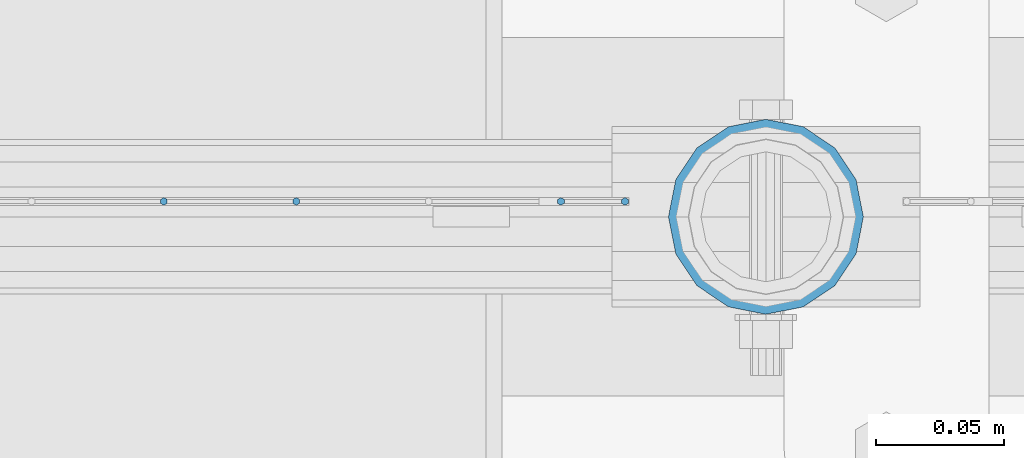
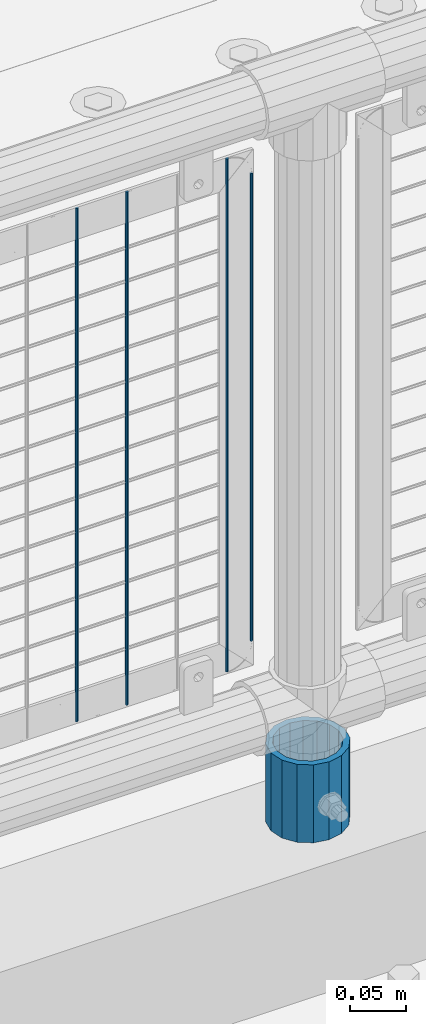
# One storey, part 84 of 240: 5 columns.
"""IFC2X3 building model written with IfcOpenShell, lengths in millimetres."""

import ifcopenshell
import ifcopenshell.guid

model = None  # the IFC model being written
_history = None  # IfcOwnerHistory: only IFC2X3 demands one
_inside = {}  # id of a spatial element -> (the spatial element, [elements in it])
_under = {}  # id of a project, library or spatial element -> (it, [spatial elements below it])
_declared = {}  # id of a project -> (the project, [libraries it declares])
_typed = {}  # id of a type object -> (the type object, [elements of that type])
_made_of = {}  # id of a material, layer set ... -> (it, [elements and type objects made of it])


def new_model(schema):
    """Start an empty IFC model of exactly this schema.

    Asked for "IFC4X3", IfcOpenShell would pick the latest addendum, in which some entities
    have other attributes; the version numbers below select the first issue.
    IFC2X3 requires an IfcOwnerHistory on every rooted entity: one is made here for all.
    """
    global model, _history
    if schema == "IFC4X3":
        model = ifcopenshell.file(schema_version=(4, 3, 0, 0))
    else:
        model = ifcopenshell.file(schema=schema)
    _inside.clear()
    _under.clear()
    _declared.clear()
    _typed.clear()
    _made_of.clear()
    _history = None
    if model.schema == "IFC2X3":
        org = make("IfcOrganization", Name="unknown")
        user = make(
            "IfcPersonAndOrganization",
            ThePerson=make("IfcPerson", FamilyName="unknown"),
            TheOrganization=org,
        )
        app = make(
            "IfcApplication",
            ApplicationDeveloper=org,
            Version="unknown",
            ApplicationFullName="unknown",
            ApplicationIdentifier="unknown",
        )
        _history = make(
            "IfcOwnerHistory",
            OwningUser=user,
            OwningApplication=app,
            ChangeAction="ADDED",
            CreationDate=0,
        )
    return model


def make(cls, **values):
    """One entity of the class cls with the attributes given. An attribute that is None is left unset."""
    return model.create_entity(
        cls, **{name: value for name, value in values.items() if value is not None}
    )


def rooted(cls, **values):
    """An entity with a GlobalId (a new one), such as an element, a storey or a relation."""
    return make(cls, GlobalId=ifcopenshell.guid.new(), OwnerHistory=_history, **values)


def si_unit(unit_type, name, prefix=None):
    """IfcSIUnit, for example si_unit("LENGTHUNIT", "METRE", prefix="MILLI")."""
    return make("IfcSIUnit", UnitType=unit_type, Prefix=prefix, Name=name)


def assignment(units):
    """IfcUnitAssignment: the units of a project."""
    return None if units is None else make("IfcUnitAssignment", Units=units)


def point(xyz):
    """IfcCartesianPoint."""
    return None if xyz is None else make("IfcCartesianPoint", Coordinates=xyz)


def direction(xyz):
    """IfcDirection."""
    return None if xyz is None else make("IfcDirection", DirectionRatios=xyz)


def frame(location, z_axis=None, x_axis=None):
    """IfcAxis2Placement3D, a coordinate frame: its origin and axes. An axis left out is left unset."""
    return make(
        "IfcAxis2Placement3D",
        Location=point(location),
        Axis=direction(z_axis),
        RefDirection=direction(x_axis),
    )


def origin_with_axes():
    """The frame at (0, 0, 0) with the z axis (0, 0, 1) and the x axis (1, 0, 0) written out."""
    return frame((0.0, 0.0, 0.0), z_axis=(0.0, 0.0, 1.0), x_axis=(1.0, 0.0, 0.0))


def place(relative_to, where):
    """IfcLocalPlacement: puts the frame where relative to a parent placement (None: the world)."""
    return make(
        "IfcLocalPlacement", PlacementRelTo=relative_to, RelativePlacement=where
    )


def context(
    kind, dimensions, precision=None, world=None, true_north=None, identifier=None
):
    """IfcGeometricRepresentationContext, for example the 3D "Model" context."""
    return make(
        "IfcGeometricRepresentationContext",
        ContextIdentifier=identifier,
        ContextType=kind,
        CoordinateSpaceDimension=dimensions,
        Precision=precision,
        WorldCoordinateSystem=world,
        TrueNorth=true_north,
    )


def subcontext(parent, identifier, kind, view, scale=None):
    """IfcGeometricRepresentationSubContext, for example "Body" below "Model"."""
    return make(
        "IfcGeometricRepresentationSubContext",
        ContextIdentifier=identifier,
        ContextType=kind,
        ParentContext=parent,
        TargetScale=scale,
        TargetView=view,
    )


def project(units=None, contexts=None):
    """IfcProject with its units and contexts."""
    return rooted(
        "IfcProject",
        Name="project",
        RepresentationContexts=contexts,
        UnitsInContext=assignment(units),
    )


def spatial(cls, under=None, at=None, **own):
    """A site, building, storey or space (cls), placed at a placement, below another one or the project."""
    s = rooted(cls, ObjectPlacement=at, **own)
    if under is not None:
        _under.setdefault(under.id(), (under, []))[1].append(s)
    return s


def faces_of(points, faces, orient=None, outer=None):
    """IfcFace entities. A face is a list of loops; a loop is a list of indices into points, from 0.

    orient and outer hold one flag for each loop. By default every Orientation is true, the
    first loop of a face is its IfcFaceOuterBound and the others are IfcFaceBound.
    """
    made = []
    for i, loops in enumerate(faces):
        bounds = []
        for j, loop in enumerate(loops):
            is_outer = j == 0 if outer is None else outer[i][j]
            bounds.append(
                make(
                    "IfcFaceOuterBound" if is_outer else "IfcFaceBound",
                    Bound=make("IfcPolyLoop", Polygon=[points[k] for k in loop]),
                    Orientation=True if orient is None else orient[i][j],
                )
            )
        made.append(make("IfcFace", Bounds=bounds))
    return made


def faceted_brep(points, faces, orient=None, outer=None, voids=None):
    """IfcFacetedBrep: a solid bounded by flat faces; with voids (closed shells), ...WithVoids."""
    shared = [point(p) for p in points]
    hull = make("IfcClosedShell", CfsFaces=faces_of(shared, faces, orient, outer))
    if voids is None:
        return make("IfcFacetedBrep", Outer=hull)
    return make(
        "IfcFacetedBrepWithVoids",
        Outer=hull,
        Voids=[
            make(cls, CfsFaces=faces_of(shared, fs, o, b)) for cls, fs, o, b in voids
        ],
    )


def shape(context_of_items, identifier, shape_type, items):
    """IfcShapeRepresentation: the items that make up one representation, for example the "Body"."""
    return make(
        "IfcShapeRepresentation",
        ContextOfItems=context_of_items,
        RepresentationIdentifier=identifier,
        RepresentationType=shape_type,
        Items=items,
    )


def material(Name=None, Category=None):
    """IfcMaterial."""
    return make("IfcMaterial", Name=Name, Category=Category)


def made_of(thing, what):
    """Note that an element or type object is made of a material, layer set ...; save() writes the relation."""
    if what is not None:
        _made_of.setdefault(what.id(), (what, []))[1].append(thing)
    return thing


def type_object(cls, material=None, **own):
    """A type object (cls), such as IfcWallType, which elements share."""
    return made_of(rooted(cls, **own), material)


def element(
    cls,
    number,
    at=None,
    inside=None,
    cuts=None,
    type_object=None,
    material=None,
    context=None,
    identifier="Body",
    shape_type=None,
    held_by="IfcProductDefinitionShape",
    body=None,
    shapes=None,
    **own,
):
    """One element of the class cls, such as IfcWall. Its Tag is "e" and its number.

    at: its placement. inside: the storey or other place that contains it. cuts: it is an
    opening in that element (IfcRelVoidsElement). A single representation is given by context,
    identifier, shape_type and body (its items); several are given by shapes. held_by: the class
    of the entity that holds the representations. save() writes the other relations.
    """
    e = rooted(cls, Tag="e%d" % number, ObjectPlacement=at, **own)
    if body is not None:
        shapes = [shape(context, identifier, shape_type, body)]
    if shapes is not None:
        e.Representation = make(held_by, Representations=shapes)
    if inside is not None:
        _inside.setdefault(inside.id(), (inside, []))[1].append(e)
    if cuts is not None:
        rooted(
            "IfcRelVoidsElement", RelatingBuildingElement=cuts, RelatedOpeningElement=e
        )
    if type_object is not None:
        _typed.setdefault(type_object.id(), (type_object, []))[1].append(e)
    return made_of(e, material)


def aggregate(whole, parts):
    """IfcRelAggregates: a whole, such as a stair, and the parts it consists of."""
    return rooted("IfcRelAggregates", RelatingObject=whole, RelatedObjects=parts)


def save(model, path):
    """Write the relations noted so far, then the file.

    IfcRelAggregates (storeys below a building ...), IfcRelContainedInSpatialStructure (elements
    in a storey), IfcRelDefinesByType, IfcRelAssociatesMaterial and IfcRelDeclares: one each for
    every whole, place, type object, material and project.
    """
    for whole, parts in _under.values():
        aggregate(whole, parts)
    for where, things in _inside.values():
        rooted(
            "IfcRelContainedInSpatialStructure",
            RelatedElements=things,
            RelatingStructure=where,
        )
    for kind, things in _typed.values():
        rooted("IfcRelDefinesByType", RelatedObjects=things, RelatingType=kind)
    for what, things in _made_of.values():
        rooted("IfcRelAssociatesMaterial", RelatedObjects=things, RelatingMaterial=what)
    for by, libraries in _declared.values():
        rooted("IfcRelDeclares", RelatingContext=by, RelatedDefinitions=libraries)
    model.write(path)


model = new_model("IFC2X3")

# Units and contexts
model_context = context("Model", 3, precision=1e-05, world=origin_with_axes())
body_context = subcontext(model_context, "Body", "Model", "MODEL_VIEW")
ifc_project = project(units=[si_unit("LENGTHUNIT", "METRE", prefix="MILLI"), si_unit("AREAUNIT", "SQUARE_METRE"), si_unit("VOLUMEUNIT", "CUBIC_METRE"), si_unit("MASSUNIT", "GRAM", prefix="KILO"), si_unit("TIMEUNIT", "SECOND"), si_unit("PLANEANGLEUNIT", "RADIAN"), si_unit("SOLIDANGLEUNIT", "STERADIAN"), si_unit("THERMODYNAMICTEMPERATUREUNIT", "DEGREE_CELSIUS"), si_unit("LUMINOUSINTENSITYUNIT", "LUMEN")], contexts=[model_context])

# Site, building, storey
site_placement = place(None, origin_with_axes())
site = spatial("IfcSite", under=ifc_project, at=site_placement, CompositionType="ELEMENT")
building_placement = place(site_placement, origin_with_axes())
building = spatial("IfcBuilding", under=site, at=building_placement, Name="Standard", CompositionType="ELEMENT")
storey_placement = place(building_placement, origin_with_axes())
storey = spatial("IfcBuildingStorey", under=building, at=storey_placement, Name="Undefined", CompositionType="ELEMENT", Elevation=0.0)

# Columns
ifc_material_1 = material(Name="Misc_Undefined")
column_type_1 = type_object("IfcColumnType", Name="D3", PredefinedType="NOTDEFINED")
for number, where, z_axis, x_axis in (
    (1, (49519.685, 34670.5, 353.02), (-1.0, 0.0, 0.0), (0.0, 0.0, 1.0)),
    (2, (49468.03, 34670.5, 353.02), (-1.0, 0.0, 0.0), (0.0, 0.0, 1.0)),
    (3, (49622.995, 34670.5, 353.02), (-1.0, 0.0, 0.0), (0.0, 0.0, 1.0)),
):
    element("IfcColumn", number, at=place(storey_placement, frame(where, z_axis=z_axis, x_axis=x_axis)), inside=storey, type_object=column_type_1, material=ifc_material_1, ObjectType="D3", context=body_context, shape_type="Brep", body=[
        faceted_brep([(-7.27595761418343e-12, -1.49999999999272, 0.0), (-7.27595761418343e-12, -0.749999999992724, -1.29903810567669), (560.0, -0.75, -1.29903810567339), (560.0, -1.5, 0.0), (0.0, 0.750000000007276, -1.29903810567669), (560.0, 0.75, -1.29903810567339), (0.0, 1.50000000000728, 0.0), (560.0, 1.5, 0.0), (0.0, 0.750000000007276, 1.29903810567669), (560.0, 0.75, 1.29903810567339), (-7.27595761418343e-12, -0.749999999992724, 1.29903810567669), (560.0, -0.75, 1.29903810567339)], [[[0, 1, 2, 3]], [[1, 4, 5, 2]], [[4, 6, 7, 5]], [[6, 8, 9, 7]], [[8, 10, 11, 9]], [[10, 0, 3, 11]], [[5, 7, 9, 11, 3, 2]], [[10, 8, 6, 4, 1, 0]]]),
    ])
column_1_placement = place(storey_placement, frame((49648.0, 34670.5, 378.02), z_axis=(-1.0, 0.0, 0.0), x_axis=(0.0, 0.0, 1.0)))
element("IfcColumn", 4, at=column_1_placement, inside=storey, type_object=column_type_1, material=ifc_material_1, ObjectType="D3", context=body_context, shape_type="Brep", body=[
    faceted_brep([(-7.27595761418343e-12, -1.49999999999272, 0.0), (-7.27595761418343e-12, -0.749999999992724, -1.29903810567669), (510.0, -0.75, -1.29903810567339), (510.0, -1.5, 0.0), (0.0, 0.750000000007276, -1.29903810567669), (510.0, 0.75, -1.29903810567339), (0.0, 1.50000000000728, 0.0), (510.0, 1.5, 0.0), (0.0, 0.750000000007276, 1.29903810567669), (510.0, 0.75, 1.29903810567339), (-7.27595761418343e-12, -0.749999999992724, 1.29903810567669), (510.0, -0.75, 1.29903810567339)], [[[0, 1, 2, 3]], [[1, 4, 5, 2]], [[4, 6, 7, 5]], [[6, 8, 9, 7]], [[8, 10, 11, 9]], [[10, 0, 3, 11]], [[5, 7, 9, 11, 3, 2]], [[10, 8, 6, 4, 1, 0]]]),
])
ifc_material_2 = material()
column_type_2 = type_object("IfcColumnType", PredefinedType="NOTDEFINED")
column_2_placement = place(storey_placement, frame((49703.0, 34664.5, 168.02), z_axis=(0.0, 1.0, 0.0), x_axis=(0.0, 0.0, 1.0)))
element("IfcColumn", 5, at=column_2_placement, inside=storey, type_object=column_type_2, material=ifc_material_2, context=body_context, shape_type="Brep", body=[
    faceted_brep([(0.0, -31.75, 0.0), (0.0, -29.3331751572332, 12.1501989775934), (85.0, -29.3331751572332, 12.1501989775934), (85.0, -31.75, 0.0), (0.0, -22.4506403026753, 22.4506403026753), (85.0, -22.4506403026753, 22.4506403026753), (0.0, -12.1501989775934, 29.3331751572332), (85.0, -12.1501989775934, 29.3331751572332), (0.0, 0.0, 31.75), (85.0, 0.0, 31.75), (0.0, 12.1501989775934, 29.3331751572332), (85.0, 12.1501989775934, 29.3331751572332), (0.0, 22.4506403026753, 22.4506403026753), (85.0, 22.4506403026753, 22.4506403026753), (0.0, 29.3331751572332, 12.1501989775934), (85.0, 29.3331751572332, 12.1501989775934), (0.0, 31.75, 0.0), (85.0, 31.75, 0.0), (0.0, 29.3331751572332, -12.1501989775934), (85.0, 29.3331751572332, -12.1501989775934), (0.0, 22.4506403026753, -22.4506403026753), (85.0, 22.4506403026753, -22.4506403026753), (0.0, 12.1501989775934, -29.3331751572332), (85.0, 12.1501989775934, -29.3331751572332), (0.0, 0.0, -31.75), (85.0, 0.0, -31.75), (0.0, -12.1501989775934, -29.3331751572332), (85.0, -12.1501989775934, -29.3331751572332), (0.0, -22.4506403026753, -22.4506403026753), (85.0, -22.4506403026753, -22.4506403026753), (0.0, -29.3331751572332, -12.1501989775934), (85.0, -29.3331751572332, -12.1501989775934), (0.0, -38.0500000000029, 0.0), (0.0, -35.1536162120537, -14.5611046014892), (85.0, -35.1536162120537, -14.5611046014892), (85.0, -38.0500000000029, 0.0), (0.0, -26.9054130241493, -26.9054130241493), (85.0, -26.9054130241493, -26.9054130241493), (0.0, -14.5611046014892, -35.1536162120537), (85.0, -14.5611046014892, -35.1536162120537), (0.0, 0.0, -38.0500000000029), (85.0, 0.0, -38.0500000000029), (0.0, 14.5611046014892, -35.1536162120537), (85.0, 14.5611046014892, -35.1536162120537), (0.0, 26.9054130241493, -26.9054130241493), (85.0, 26.9054130241493, -26.9054130241493), (0.0, 35.1536162120537, -14.5611046014892), (85.0, 35.1536162120537, -14.5611046014892), (0.0, 38.0500000000029, 0.0), (85.0, 38.0500000000029, 0.0), (0.0, 35.1536162120537, 14.5611046014892), (85.0, 35.1536162120537, 14.5611046014892), (0.0, 26.9054130241493, 26.9054130241493), (85.0, 26.9054130241493, 26.9054130241493), (0.0, 14.5611046014892, 35.1536162120537), (85.0, 14.5611046014892, 35.1536162120537), (0.0, 0.0, 38.0500000000029), (85.0, 0.0, 38.0500000000029), (0.0, -14.5611046014892, 35.1536162120537), (85.0, -14.5611046014892, 35.1536162120537), (0.0, -26.9054130241493, 26.9054130241493), (85.0, -26.9054130241493, 26.9054130241493), (0.0, -35.1536162120537, 14.5611046014892), (85.0, -35.1536162120537, 14.5611046014892)], [[[0, 1, 2, 3]], [[1, 4, 5, 2]], [[4, 6, 7, 5]], [[6, 8, 9, 7]], [[8, 10, 11, 9]], [[10, 12, 13, 11]], [[12, 14, 15, 13]], [[14, 16, 17, 15]], [[16, 18, 19, 17]], [[18, 20, 21, 19]], [[20, 22, 23, 21]], [[22, 24, 25, 23]], [[24, 26, 27, 25]], [[26, 28, 29, 27]], [[28, 30, 31, 29]], [[30, 0, 3, 31]], [[32, 33, 34, 35]], [[33, 36, 37, 34]], [[36, 38, 39, 37]], [[38, 40, 41, 39]], [[40, 42, 43, 41]], [[42, 44, 45, 43]], [[44, 46, 47, 45]], [[46, 48, 49, 47]], [[48, 50, 51, 49]], [[50, 52, 53, 51]], [[52, 54, 55, 53]], [[54, 56, 57, 55]], [[56, 58, 59, 57]], [[58, 60, 61, 59]], [[60, 62, 63, 61]], [[62, 32, 35, 63]], [[37, 39, 41, 43, 45, 47, 49, 51, 53, 55, 57, 59, 61, 63, 35, 34], [5, 7, 9, 11, 13, 15, 17, 19, 21, 23, 25, 27, 29, 31, 3, 2]], [[62, 60, 58, 56, 54, 52, 50, 48, 46, 44, 42, 40, 38, 36, 33, 32], [30, 28, 26, 24, 22, 20, 18, 16, 14, 12, 10, 8, 6, 4, 1, 0]]]),
])

save(model, "model.ifc")
